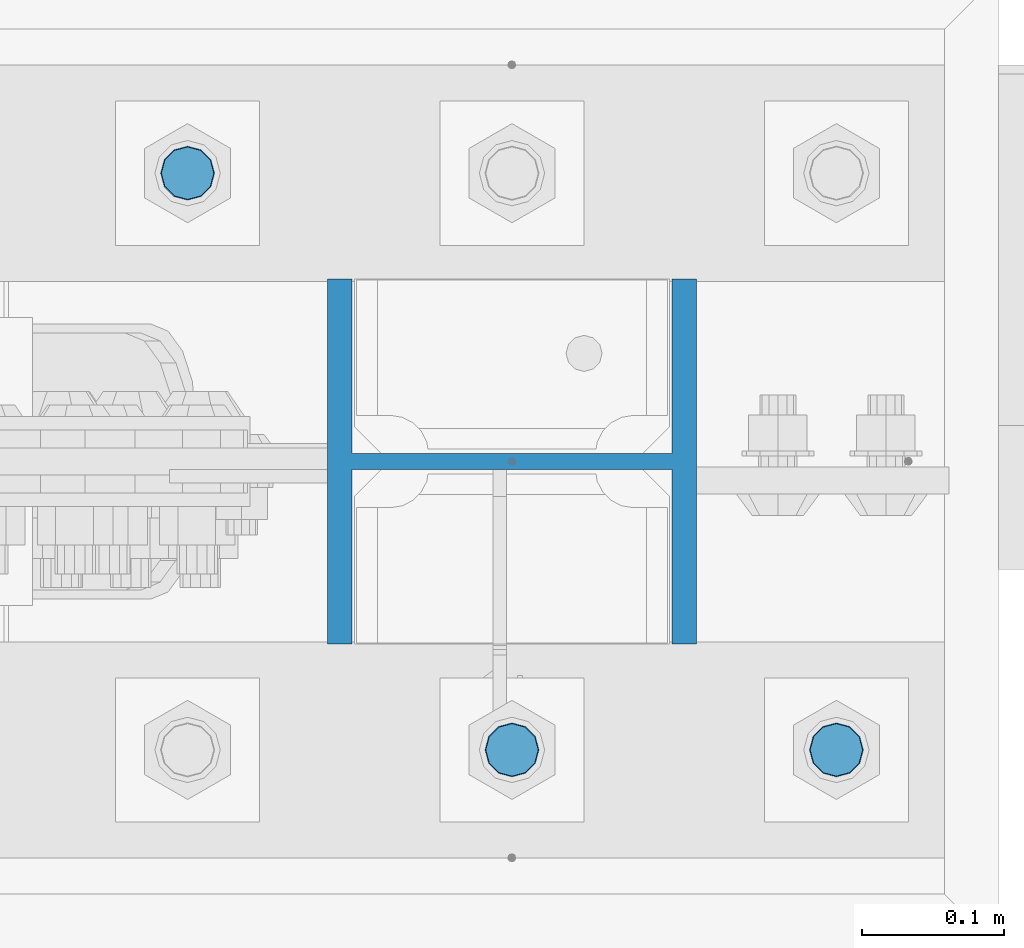
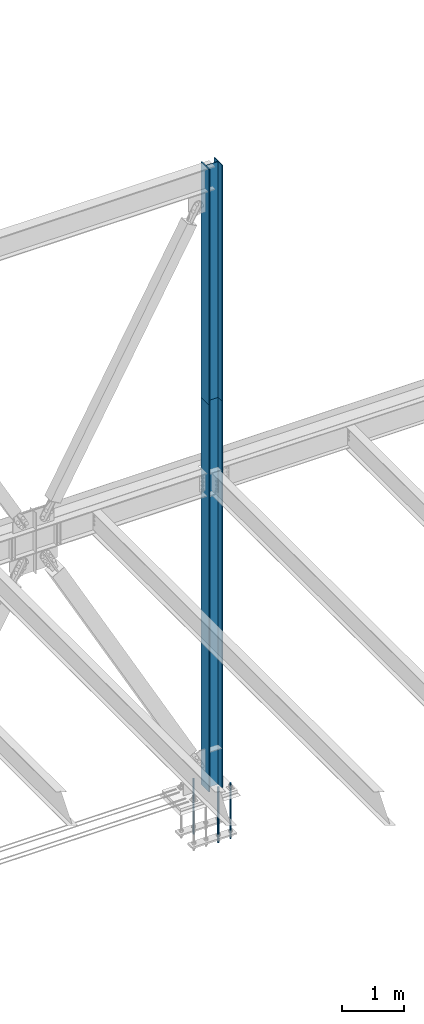
# One storey, part 1400 of 3843: 5 columns, 3 elements without a shape of their own.
"""IFC2X3 building model written with IfcOpenShell, lengths in millimetres."""

from ifc_helpers import new_model, si_unit, frame, origin_with_axes, place, context, subcontext, project, spatial, faceted_brep, material, type_object, element, aggregate, save


model = new_model("IFC2X3")

# Units and contexts
model_context = context("Model", 3, precision=1e-05, world=origin_with_axes())
body_context = subcontext(model_context, "Body", "Model", "MODEL_VIEW")
ifc_project = project(units=[si_unit("LENGTHUNIT", "METRE", prefix="MILLI"), si_unit("AREAUNIT", "SQUARE_METRE"), si_unit("VOLUMEUNIT", "CUBIC_METRE"), si_unit("MASSUNIT", "GRAM", prefix="KILO"), si_unit("TIMEUNIT", "SECOND"), si_unit("PLANEANGLEUNIT", "RADIAN"), si_unit("SOLIDANGLEUNIT", "STERADIAN"), si_unit("THERMODYNAMICTEMPERATUREUNIT", "DEGREE_CELSIUS"), si_unit("LUMINOUSINTENSITYUNIT", "LUMEN")], contexts=[model_context])

# Site, building, storey
site_placement = place(None, origin_with_axes())
site = spatial("IfcSite", under=ifc_project, at=site_placement, CompositionType="ELEMENT")
building_placement = place(site_placement, origin_with_axes())
building = spatial("IfcBuilding", under=site, at=building_placement, Name="Undefined", CompositionType="ELEMENT")
storey_placement = place(building_placement, origin_with_axes())
storey = spatial("IfcBuildingStorey", under=building, at=storey_placement, Name="Undefined", CompositionType="ELEMENT", Elevation=0.0)

# Assembly, column
assembly_1_placement = place(storey_placement, origin_with_axes())
assembly_1 = element("IfcElementAssembly", 1, at=assembly_1_placement, inside=storey, Name="CB", AssemblyPlace="NOTDEFINED", PredefinedType="RIGID_FRAME")
ifc_material_1 = material(Name="STEEL/A992")
column_type_1 = type_object("IfcColumnType", Name="W10X60", PredefinedType="NOTDEFINED")
column_1_placement = place(assembly_1_placement, frame((62636.4, 104559.1, 37795.2), z_axis=(-1.0, 0.0, 0.0), x_axis=(0.0, 0.0, 1.0)))
column_1 = element("IfcColumn", 2, at=column_1_placement, type_object=column_type_1, material=ifc_material_1, Name="COLUMN", ObjectType="W10X60", context=body_context, shape_type="Brep", body=[
    faceted_brep([(0.0, 128.587499999994, -130.174999999999), (0.0, 128.587499999994, -112.712500000001), (4673.60000000001, 128.587499999994, -112.712500000001), (4673.60000000001, 128.587499999994, -130.174999999999), (0.0, 5.55624999999418, -112.712500000001), (4673.60000000001, 5.55624999999418, -112.712500000001), (0.0, 5.55624999999418, 112.712500000001), (4673.60000000001, 5.55624999999418, 112.712500000001), (0.0, 128.587499999994, 112.712500000001), (4673.60000000001, 128.587499999994, 112.712500000001), (0.0, 128.587499999994, 130.174999999999), (4673.60000000001, 128.587499999994, 130.174999999999), (0.0, -128.587499999994, 130.174999999999), (4673.60000000001, -128.587499999994, 130.174999999999), (0.0, -128.587499999994, 112.712500000001), (4673.60000000001, -128.587499999994, 112.712500000001), (0.0, -5.55624999999418, 112.712500000001), (4673.60000000001, -5.55624999999418, 112.712500000001), (0.0, -5.55624999999418, -112.712500000001), (4673.60000000001, -5.55624999999418, -112.712500000001), (0.0, -128.587499999994, -112.712500000001), (4673.60000000001, -128.587499999994, -112.712500000001), (0.0, -128.587499999994, -130.174999999999), (4673.60000000001, -128.587499999994, -130.174999999999)], [[[0, 1, 2, 3]], [[1, 4, 5, 2]], [[4, 6, 7, 5]], [[6, 8, 9, 7]], [[8, 10, 11, 9]], [[10, 12, 13, 11]], [[12, 14, 15, 13]], [[14, 16, 17, 15]], [[16, 18, 19, 17]], [[18, 20, 21, 19]], [[20, 22, 23, 21]], [[22, 0, 3, 23]], [[5, 7, 9, 11, 13, 15, 17, 19, 21, 23, 3, 2]], [[22, 20, 18, 16, 14, 12, 10, 8, 6, 4, 1, 0]]]),
])
aggregate(assembly_1, [column_1])

assembly_2_placement = place(storey_placement, origin_with_axes())
assembly_2 = element("IfcElementAssembly", 3, at=assembly_2_placement, inside=storey, Name="COLUMN", AssemblyPlace="NOTDEFINED", PredefinedType="RIGID_FRAME")
column_2_placement = place(assembly_2_placement, frame((62636.4, 104559.1, 30022.8), z_axis=(-1.0, 0.0, 0.0), x_axis=(0.0, 0.0, 1.0)))
column_2 = element("IfcColumn", 4, at=column_2_placement, type_object=column_type_1, material=ifc_material_1, Name="COLUMN", ObjectType="W10X60", context=body_context, shape_type="Brep", body=[
    faceted_brep([(101.599999999999, 128.587499999994, -130.174999999999), (101.599999999999, 128.587499999994, -112.712500000001), (7772.4, 128.587499999994, -112.712500000001), (7772.4, 128.587499999994, -130.174999999999), (101.599999999999, 5.55624999999418, -112.712500000001), (7772.4, 5.55624999999418, -112.712500000001), (101.599999999999, 5.55624999999418, 112.712500000001), (7772.4, 5.55624999999418, 112.712500000001), (101.599999999999, 128.587499999994, 112.712500000001), (7772.4, 128.587499999994, 112.712500000001), (101.599999999999, 128.587499999994, 130.174999999999), (7772.4, 128.587499999994, 130.174999999999), (101.599999999999, -128.587499999994, 130.174999999999), (7772.4, -128.587499999994, 130.174999999999), (101.599999999999, -128.587499999994, 112.712500000001), (7772.4, -128.587499999994, 112.712500000001), (101.599999999999, -5.55624999999418, 112.712500000001), (7772.4, -5.55624999999418, 112.712500000001), (101.599999999999, -5.55624999999418, -112.712500000001), (7772.4, -5.55624999999418, -112.712500000001), (101.599999999999, -128.587499999994, -112.712500000001), (7772.4, -128.587499999994, -112.712500000001), (101.599999999999, -128.587499999994, -130.174999999999), (7772.4, -128.587499999994, -130.174999999999)], [[[0, 1, 2, 3]], [[1, 4, 5, 2]], [[4, 6, 7, 5]], [[6, 8, 9, 7]], [[8, 10, 11, 9]], [[10, 12, 13, 11]], [[12, 14, 15, 13]], [[14, 16, 17, 15]], [[16, 18, 19, 17]], [[18, 20, 21, 19]], [[20, 22, 23, 21]], [[22, 0, 3, 23]], [[5, 7, 9, 11, 13, 15, 17, 19, 21, 23, 3, 2]], [[22, 20, 18, 16, 14, 12, 10, 8, 6, 4, 1, 0]]]),
])
aggregate(assembly_2, [column_2])

# Assembly, columns
assembly_3_placement = place(storey_placement, origin_with_axes())
assembly_3 = element("IfcElementAssembly", 5, at=assembly_3_placement, inside=storey, Name="TEMPLATE", AssemblyPlace="NOTDEFINED", PredefinedType="RIGID_FRAME")
ifc_material_2 = material(Name="Undefined/F1554-GR.55")
column_type_2 = type_object("IfcColumnType", PredefinedType="NOTDEFINED")
column_3_placement = place(assembly_3_placement, frame((62865.0, 104355.9, 30022.8), z_axis=(1.0, 0.0, 0.0), x_axis=(0.0, 0.0, -1.0)))
column_3 = element("IfcColumn", 6, at=column_3_placement, type_object=column_type_2, material=ifc_material_2, Name="ANCHOR_ROD", context=body_context, shape_type="Brep", body=[
    faceted_brep([(-209.549999999999, -16.0214699700155, 9.25), (-209.549999999999, -9.25, 16.0214699700118), (-209.549999999999, 0.0, 18.5), (-209.549999999999, 9.25, 16.0214699700118), (-209.549999999999, 16.0214699700155, 9.25), (-209.549999999999, 18.5, 0.0), (-209.549999999999, 16.0214699700155, -9.25), (-209.549999999999, 9.25, -16.0214699700118), (-209.549999999999, 0.0, -18.5), (-209.549999999999, -9.25, -16.0214699700118), (-209.549999999999, -16.0214699700155, -9.25), (-209.549999999999, -18.5, 0.0), (0.0, 18.5, 0.0), (0.0, 16.0214699700118, -9.25), (0.0, 9.25, -16.0214699700155), (0.0, 0.0, -18.5), (0.0, -9.25, -16.0214699700155), (0.0, -16.0214699700118, -9.25), (0.0, -18.5, 0.0), (0.0, -16.0214699700118, 9.25), (0.0, -9.25, 16.0214699700155), (0.0, 0.0, 18.5), (0.0, 9.25, 16.0214699700155), (0.0, 16.0214699700118, 9.25), (0.0, -16.4977839420972, 9.52500000000146), (0.0, -9.52500000000146, 16.4977839420972), (0.0, 0.0, 19.0499989999989), (0.0, 9.52500000000146, 16.4977839420972), (0.0, 16.4977839420972, 9.52500000000146), (0.0, 19.0500000000029, 0.0), (0.0, 16.4977839420972, -9.52500000000146), (0.0, 9.52500000000146, -16.4977839420972), (0.0, 0.0, -19.0499989999989), (0.0, -9.52500000000146, -16.4977839420972), (0.0, -16.4977839420972, -9.52500000000146), (0.0, -19.0500000000029, 0.0), (698.5, -19.0499999999993, 0.0), (698.5, -16.4977839420935, 9.52499999999418), (698.5, -9.52500000000146, 16.4977839420899), (698.5, 0.0, 19.0500000000029), (698.5, 9.52500000000146, 16.4977839420899), (698.5, 16.4977839420935, 9.52499999999418), (698.5, 19.0499999999993, 0.0), (698.5, 16.4977839420935, -9.52499999999418), (698.5, 9.52500000000146, -16.4977839420899), (698.5, 0.0, -19.0500000000029), (698.5, -9.52500000000146, -16.4977839420899), (698.5, -16.4977839420935, -9.52499999999418), (698.5, -9.25, 16.0214699700155), (698.5, 0.0, 18.5), (698.5, 9.25, 16.0214699700155), (698.5, 16.0214699700118, 9.25), (698.5, 18.5, 0.0), (698.5, 16.0214699700118, -9.25), (698.5, 9.25, -16.0214699700155), (698.5, 0.0, -18.5), (698.5, -9.25, -16.0214699700155), (698.5, -16.0214699700118, -9.25), (698.5, -18.5, 0.0), (698.5, -16.0214699700118, 9.25), (889.0, -9.25, -16.0214699700155), (889.0, 0.0, -18.5), (889.0, 9.25, -16.0214699700155), (889.0, 16.0214699700118, -9.25), (889.0, 18.5, 0.0), (889.0, 16.0214699700118, 9.25), (889.0, 9.25, 16.0214699700155), (889.0, 0.0, 18.5), (889.0, -9.25, 16.0214699700155), (889.0, -16.0214699700118, 9.25), (889.0, -18.5, 0.0), (889.0, -16.0214699700118, -9.25)], [[[0, 1, 2, 3, 4, 5, 6, 7, 8, 9, 10, 11]], [[6, 5, 12, 13]], [[7, 6, 13, 14]], [[8, 7, 14, 15]], [[9, 8, 15, 16]], [[10, 9, 16, 17]], [[11, 10, 17, 18]], [[0, 11, 18, 19]], [[1, 0, 19, 20]], [[2, 1, 20, 21]], [[3, 2, 21, 22]], [[4, 3, 22, 23]], [[5, 4, 23, 12]], [[24, 25, 26, 27, 28, 29, 30, 31, 32, 33, 34, 35], [22, 21, 20, 19, 18, 17, 16, 15, 14, 13, 12, 23]], [[24, 35, 36, 37]], [[25, 24, 37, 38]], [[26, 25, 38, 39]], [[27, 26, 39, 40]], [[28, 27, 40, 41]], [[29, 28, 41, 42]], [[30, 29, 42, 43]], [[31, 30, 43, 44]], [[32, 31, 44, 45]], [[33, 32, 45, 46]], [[34, 33, 46, 47]], [[35, 34, 47, 36]], [[46, 45, 44, 43, 42, 41, 40, 39, 38, 37, 36, 47], [48, 49, 50, 51, 52, 53, 54, 55, 56, 57, 58, 59]], [[60, 61, 62, 63, 64, 65, 66, 67, 68, 69, 70, 71]], [[68, 67, 49, 48]], [[69, 68, 48, 59]], [[70, 69, 59, 58]], [[71, 70, 58, 57]], [[60, 71, 57, 56]], [[61, 60, 56, 55]], [[62, 61, 55, 54]], [[63, 62, 54, 53]], [[64, 63, 53, 52]], [[65, 64, 52, 51]], [[66, 65, 51, 50]], [[67, 66, 50, 49]]]),
])
column_4_placement = place(assembly_3_placement, frame((62636.4, 104355.9, 30022.8), z_axis=(1.0, 0.0, 0.0), x_axis=(0.0, 0.0, -1.0)))
column_4 = element("IfcColumn", 7, at=column_4_placement, type_object=column_type_2, material=ifc_material_2, Name="ANCHOR_ROD", context=body_context, shape_type="Brep", body=[
    faceted_brep([(-209.549999999999, -16.0214699700155, 9.25), (-209.549999999999, -9.25, 16.0214699700118), (-209.549999999999, 0.0, 18.5), (-209.549999999999, 9.25, 16.0214699700118), (-209.549999999999, 16.0214699700155, 9.25), (-209.549999999999, 18.5, 0.0), (-209.549999999999, 16.0214699700155, -9.25), (-209.549999999999, 9.25, -16.0214699700118), (-209.549999999999, 0.0, -18.5), (-209.549999999999, -9.25, -16.0214699700118), (-209.549999999999, -16.0214699700155, -9.25), (-209.549999999999, -18.5, 0.0), (0.0, 18.5, 0.0), (0.0, 16.0214699700118, -9.25), (0.0, 9.25, -16.0214699700155), (0.0, 0.0, -18.5), (0.0, -9.25, -16.0214699700155), (0.0, -16.0214699700118, -9.25), (0.0, -18.5, 0.0), (0.0, -16.0214699700118, 9.25), (0.0, -9.25, 16.0214699700155), (0.0, 0.0, 18.5), (0.0, 9.25, 16.0214699700155), (0.0, 16.0214699700118, 9.25), (0.0, -16.4977839420972, 9.52500000000146), (0.0, -9.52500000000146, 16.4977839420972), (0.0, 0.0, 19.0499989999989), (0.0, 9.52500000000146, 16.4977839420972), (0.0, 16.4977839420972, 9.52500000000146), (0.0, 19.0500000000029, 0.0), (0.0, 16.4977839420972, -9.52500000000146), (0.0, 9.52500000000146, -16.4977839420972), (0.0, 0.0, -19.0499989999989), (0.0, -9.52500000000146, -16.4977839420972), (0.0, -16.4977839420972, -9.52500000000146), (0.0, -19.0500000000029, 0.0), (698.5, -19.0499999999993, 0.0), (698.5, -16.4977839420935, 9.52499999999418), (698.5, -9.52500000000146, 16.4977839420899), (698.5, 0.0, 19.0500000000029), (698.5, 9.52500000000146, 16.4977839420899), (698.5, 16.4977839420935, 9.52499999999418), (698.5, 19.0499999999993, 0.0), (698.5, 16.4977839420935, -9.52499999999418), (698.5, 9.52500000000146, -16.4977839420899), (698.5, 0.0, -19.0500000000029), (698.5, -9.52500000000146, -16.4977839420899), (698.5, -16.4977839420935, -9.52499999999418), (698.5, -9.25, 16.0214699700155), (698.5, 0.0, 18.5), (698.5, 9.25, 16.0214699700155), (698.5, 16.0214699700118, 9.25), (698.5, 18.5, 0.0), (698.5, 16.0214699700118, -9.25), (698.5, 9.25, -16.0214699700155), (698.5, 0.0, -18.5), (698.5, -9.25, -16.0214699700155), (698.5, -16.0214699700118, -9.25), (698.5, -18.5, 0.0), (698.5, -16.0214699700118, 9.25), (889.0, -9.25, -16.0214699700155), (889.0, 0.0, -18.5), (889.0, 9.25, -16.0214699700155), (889.0, 16.0214699700118, -9.25), (889.0, 18.5, 0.0), (889.0, 16.0214699700118, 9.25), (889.0, 9.25, 16.0214699700155), (889.0, 0.0, 18.5), (889.0, -9.25, 16.0214699700155), (889.0, -16.0214699700118, 9.25), (889.0, -18.5, 0.0), (889.0, -16.0214699700118, -9.25)], [[[0, 1, 2, 3, 4, 5, 6, 7, 8, 9, 10, 11]], [[6, 5, 12, 13]], [[7, 6, 13, 14]], [[8, 7, 14, 15]], [[9, 8, 15, 16]], [[10, 9, 16, 17]], [[11, 10, 17, 18]], [[0, 11, 18, 19]], [[1, 0, 19, 20]], [[2, 1, 20, 21]], [[3, 2, 21, 22]], [[4, 3, 22, 23]], [[5, 4, 23, 12]], [[24, 25, 26, 27, 28, 29, 30, 31, 32, 33, 34, 35], [22, 21, 20, 19, 18, 17, 16, 15, 14, 13, 12, 23]], [[24, 35, 36, 37]], [[25, 24, 37, 38]], [[26, 25, 38, 39]], [[27, 26, 39, 40]], [[28, 27, 40, 41]], [[29, 28, 41, 42]], [[30, 29, 42, 43]], [[31, 30, 43, 44]], [[32, 31, 44, 45]], [[33, 32, 45, 46]], [[34, 33, 46, 47]], [[35, 34, 47, 36]], [[46, 45, 44, 43, 42, 41, 40, 39, 38, 37, 36, 47], [48, 49, 50, 51, 52, 53, 54, 55, 56, 57, 58, 59]], [[60, 61, 62, 63, 64, 65, 66, 67, 68, 69, 70, 71]], [[68, 67, 49, 48]], [[69, 68, 48, 59]], [[70, 69, 59, 58]], [[71, 70, 58, 57]], [[60, 71, 57, 56]], [[61, 60, 56, 55]], [[62, 61, 55, 54]], [[63, 62, 54, 53]], [[64, 63, 53, 52]], [[65, 64, 52, 51]], [[66, 65, 51, 50]], [[67, 66, 50, 49]]]),
])
column_5_placement = place(assembly_3_placement, frame((62407.8, 104762.3, 30022.8), z_axis=(-1.0, 0.0, 0.0), x_axis=(0.0, 0.0, -1.0)))
column_5 = element("IfcColumn", 8, at=column_5_placement, type_object=column_type_2, material=ifc_material_2, Name="ANCHOR_ROD", context=body_context, shape_type="Brep", body=[
    faceted_brep([(-209.549999999999, -16.0214699700155, 9.25), (-209.549999999999, -9.25, 16.0214699700118), (-209.549999999999, 0.0, 18.5), (-209.549999999999, 9.25, 16.0214699700118), (-209.549999999999, 16.0214699700155, 9.25), (-209.549999999999, 18.5, 0.0), (-209.549999999999, 16.0214699700155, -9.25), (-209.549999999999, 9.25, -16.0214699700118), (-209.549999999999, 0.0, -18.5), (-209.549999999999, -9.25, -16.0214699700118), (-209.549999999999, -16.0214699700155, -9.25), (-209.549999999999, -18.5, 0.0), (0.0, 18.5, 0.0), (0.0, 16.0214699700118, -9.25), (0.0, 9.25, -16.0214699700155), (0.0, 0.0, -18.5), (0.0, -9.25, -16.0214699700155), (0.0, -16.0214699700118, -9.25), (0.0, -18.5, 0.0), (0.0, -16.0214699700118, 9.25), (0.0, -9.25, 16.0214699700155), (0.0, 0.0, 18.5), (0.0, 9.25, 16.0214699700155), (0.0, 16.0214699700118, 9.25), (0.0, -16.4977839420972, 9.52500000000146), (0.0, -9.52500000000146, 16.4977839420972), (0.0, 0.0, 19.0499989999989), (0.0, 9.52500000000146, 16.4977839420972), (0.0, 16.4977839420972, 9.52500000000146), (0.0, 19.0500000000029, 0.0), (0.0, 16.4977839420972, -9.52500000000146), (0.0, 9.52500000000146, -16.4977839420972), (0.0, 0.0, -19.0499989999989), (0.0, -9.52500000000146, -16.4977839420972), (0.0, -16.4977839420972, -9.52500000000146), (0.0, -19.0500000000029, 0.0), (698.5, -19.0499999999993, 0.0), (698.5, -16.4977839420935, 9.52499999999418), (698.5, -9.52500000000146, 16.4977839420899), (698.5, 0.0, 19.0500000000029), (698.5, 9.52500000000146, 16.4977839420899), (698.5, 16.4977839420935, 9.52499999999418), (698.5, 19.0499999999993, 0.0), (698.5, 16.4977839420935, -9.52499999999418), (698.5, 9.52500000000146, -16.4977839420899), (698.5, 0.0, -19.0500000000029), (698.5, -9.52500000000146, -16.4977839420899), (698.5, -16.4977839420935, -9.52499999999418), (698.5, -9.25, 16.0214699700155), (698.5, 0.0, 18.5), (698.5, 9.25, 16.0214699700155), (698.5, 16.0214699700118, 9.25), (698.5, 18.5, 0.0), (698.5, 16.0214699700118, -9.25), (698.5, 9.25, -16.0214699700155), (698.5, 0.0, -18.5), (698.5, -9.25, -16.0214699700155), (698.5, -16.0214699700118, -9.25), (698.5, -18.5, 0.0), (698.5, -16.0214699700118, 9.25), (889.0, -9.25, -16.0214699700155), (889.0, 0.0, -18.5), (889.0, 9.25, -16.0214699700155), (889.0, 16.0214699700118, -9.25), (889.0, 18.5, 0.0), (889.0, 16.0214699700118, 9.25), (889.0, 9.25, 16.0214699700155), (889.0, 0.0, 18.5), (889.0, -9.25, 16.0214699700155), (889.0, -16.0214699700118, 9.25), (889.0, -18.5, 0.0), (889.0, -16.0214699700118, -9.25)], [[[0, 1, 2, 3, 4, 5, 6, 7, 8, 9, 10, 11]], [[6, 5, 12, 13]], [[7, 6, 13, 14]], [[8, 7, 14, 15]], [[9, 8, 15, 16]], [[10, 9, 16, 17]], [[11, 10, 17, 18]], [[0, 11, 18, 19]], [[1, 0, 19, 20]], [[2, 1, 20, 21]], [[3, 2, 21, 22]], [[4, 3, 22, 23]], [[5, 4, 23, 12]], [[24, 25, 26, 27, 28, 29, 30, 31, 32, 33, 34, 35], [22, 21, 20, 19, 18, 17, 16, 15, 14, 13, 12, 23]], [[24, 35, 36, 37]], [[25, 24, 37, 38]], [[26, 25, 38, 39]], [[27, 26, 39, 40]], [[28, 27, 40, 41]], [[29, 28, 41, 42]], [[30, 29, 42, 43]], [[31, 30, 43, 44]], [[32, 31, 44, 45]], [[33, 32, 45, 46]], [[34, 33, 46, 47]], [[35, 34, 47, 36]], [[46, 45, 44, 43, 42, 41, 40, 39, 38, 37, 36, 47], [48, 49, 50, 51, 52, 53, 54, 55, 56, 57, 58, 59]], [[60, 61, 62, 63, 64, 65, 66, 67, 68, 69, 70, 71]], [[68, 67, 49, 48]], [[69, 68, 48, 59]], [[70, 69, 59, 58]], [[71, 70, 58, 57]], [[60, 71, 57, 56]], [[61, 60, 56, 55]], [[62, 61, 55, 54]], [[63, 62, 54, 53]], [[64, 63, 53, 52]], [[65, 64, 52, 51]], [[66, 65, 51, 50]], [[67, 66, 50, 49]]]),
])
aggregate(assembly_3, [column_3, column_4, column_5])

save(model, "model.ifc")
